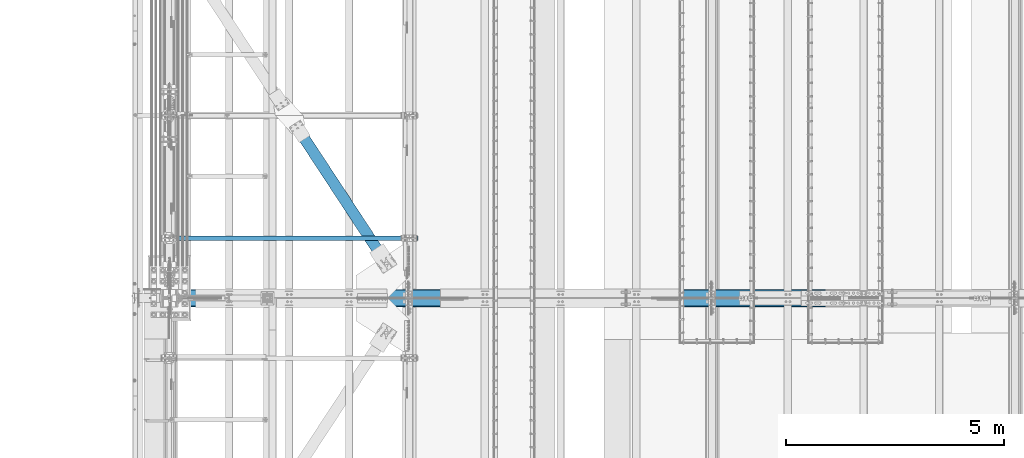
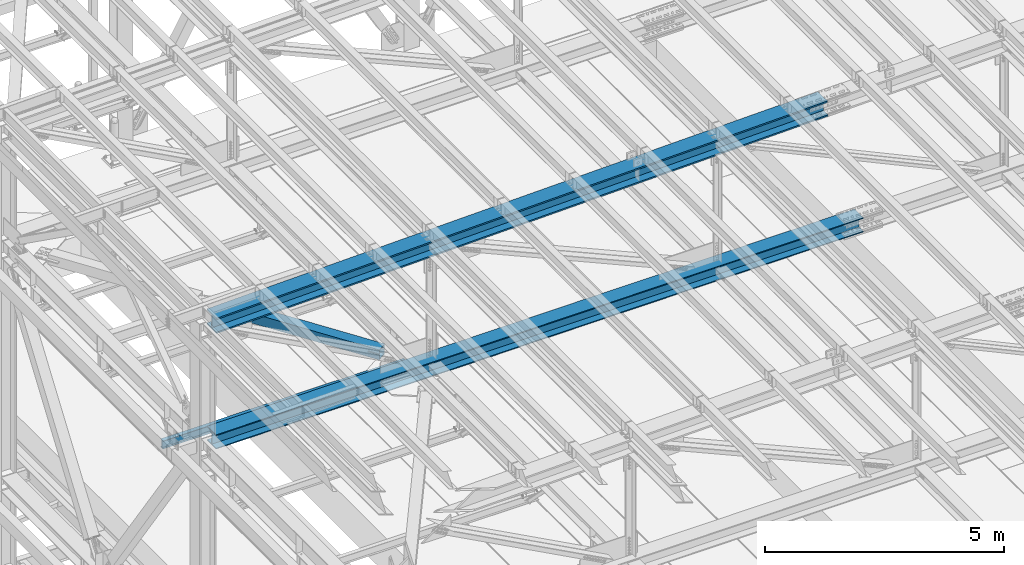
# One storey, part 1870 of 3843: 4 beams, 4 elements without a shape of their own.
"""IFC2X3 building model written with IfcOpenShell, lengths in millimetres."""

from ifc_helpers import new_model, si_unit, frame, origin_with_axes, place, context, subcontext, project, spatial, faceted_brep, material, type_object, element, aggregate, save


model = new_model("IFC2X3")

# Units and contexts
model_context = context("Model", 3, precision=1e-05, world=origin_with_axes())
body_context = subcontext(model_context, "Body", "Model", "MODEL_VIEW")
ifc_project = project(units=[si_unit("LENGTHUNIT", "METRE", prefix="MILLI"), si_unit("AREAUNIT", "SQUARE_METRE"), si_unit("VOLUMEUNIT", "CUBIC_METRE"), si_unit("MASSUNIT", "GRAM", prefix="KILO"), si_unit("TIMEUNIT", "SECOND"), si_unit("PLANEANGLEUNIT", "RADIAN"), si_unit("SOLIDANGLEUNIT", "STERADIAN"), si_unit("THERMODYNAMICTEMPERATUREUNIT", "DEGREE_CELSIUS"), si_unit("LUMINOUSINTENSITYUNIT", "LUMEN")], contexts=[model_context])

# Site, building, storey
site_placement = place(None, origin_with_axes())
site = spatial("IfcSite", under=ifc_project, at=site_placement, CompositionType="ELEMENT")
building_placement = place(site_placement, origin_with_axes())
building = spatial("IfcBuilding", under=site, at=building_placement, Name="Undefined", CompositionType="ELEMENT")
storey_placement = place(building_placement, origin_with_axes())
storey = spatial("IfcBuildingStorey", under=building, at=storey_placement, Name="Undefined", CompositionType="ELEMENT", Elevation=0.0)

# Assembly, beam
assembly_1_placement = place(storey_placement, origin_with_axes())
assembly_1 = element("IfcElementAssembly", 1, at=assembly_1_placement, inside=storey, Name="BEAM", AssemblyPlace="NOTDEFINED", PredefinedType="RIGID_FRAME")
ifc_material_1 = material(Name="STEEL/A992")
beam_type_1 = type_object("IfcBeamType", Name="W8X13", PredefinedType="NOTDEFINED")
beam_1_placement = place(assembly_1_placement, frame((36372.8, 68643.5, 41402.0), z_axis=(0.0, 0.0, 1.0), x_axis=(1.0, 0.0, 0.0)))
beam_1 = element("IfcBeam", 2, at=beam_1_placement, type_object=beam_type_1, material=ifc_material_1, Name="BEAM", ObjectType="W8X13", context=body_context, shape_type="Brep", body=[
    faceted_brep([(0.0, 50.7999999999993, -101.599999999999), (0.0, 50.7999999999993, -95.25), (5892.8, 50.7999999999993, -95.25), (5892.8, 50.7999999999993, -101.599999999999), (0.0, 3.17499999999927, -95.25), (5892.8, 3.17499999999927, -95.25), (-2.44140610448085e-05, 3.17500000000291, 95.2499999999927), (5892.8, 3.17499999999927, 95.25), (0.0, 50.7999999999993, 95.25), (5892.8, 50.7999999999993, 95.25), (0.0, 50.7999999999993, 101.599999999999), (5892.8, 50.7999999999993, 101.599999999999), (0.0, -50.7999999999993, 101.599999999999), (5892.8, -50.7999999999993, 101.599999999999), (0.0, -50.7999999999993, 95.25), (5892.8, -50.7999999999993, 95.25), (0.0, -3.17499999999927, 95.25), (5892.8, -3.17499999999927, 95.25), (0.0, -3.17499999999927, -95.25), (5892.8, -3.17499999999927, -95.25), (0.0, -50.7999999999993, -95.25), (5892.8, -50.7999999999993, -95.25), (0.0, -50.7999999999993, -101.599999999999), (5892.8, -50.7999999999993, -101.599999999999)], [[[0, 1, 2, 3]], [[1, 4, 5, 2]], [[4, 6, 7, 5]], [[6, 8, 9, 7]], [[8, 10, 11, 9]], [[10, 12, 13, 11]], [[12, 14, 15, 13]], [[14, 16, 17, 15]], [[16, 18, 19, 17]], [[18, 20, 21, 19]], [[20, 22, 23, 21]], [[22, 0, 3, 23]], [[5, 7, 9, 11, 13, 15, 17, 19, 21, 23, 3, 2]], [[22, 20, 18, 16, 14, 12, 10, 8, 6, 4, 1, 0]]]),
])
aggregate(assembly_1, [beam_1])

assembly_2_placement = place(storey_placement, origin_with_axes())
assembly_2 = element("IfcElementAssembly", 3, at=assembly_2_placement, inside=storey, Name="BEAM", AssemblyPlace="NOTDEFINED", PredefinedType="RIGID_FRAME")
beam_type_2 = type_object("IfcBeamType", Name="W14X193", PredefinedType="NOTDEFINED")
beam_2_placement = place(assembly_2_placement, frame((36581.3621945434, 67271.9, 45221.597899112), z_axis=(-0.0258271990066861, 0.0, 0.99966642225868), x_axis=(0.99966642225868, 0.0, 0.0258271990066833)))
beam_2 = element("IfcBeam", 4, at=beam_2_placement, type_object=beam_type_2, material=ifc_material_1, Name="BEAM", ObjectType="W14X193", context=body_context, shape_type="Brep", body=[
    faceted_brep([(12012.8182232807, 11.1125000000029, 163.773914461657), (12012.8182232807, 200.024999999994, 163.773914461657), (13514.4487999086, 200.024999999994, 162.270411304176), (13514.4487999086, 11.1125000000029, 162.270411304176), (10511.1872779887, 11.1125000000029, 164.847845374941), (10511.1872779887, 200.024999999994, 164.847845374941), (9009.55608692087, 11.1125000000029, 165.492203955546), (9009.55608692087, 200.024999999994, 165.492203955546), (7507.92477296503, 11.1125000000029, 165.706990152255), (7507.92477296503, 200.024999999994, 165.706990152255), (6006.29345900918, 11.1125000000029, 165.492203946436), (6006.29345900918, 200.024999999994, 165.492203946436), (4504.66226794132, 11.1125000000029, 164.847845356722), (4504.66226794132, 200.024999999994, 164.847845356722), (3003.03132264942, 11.1125000000029, 163.773914434329), (3003.03132264942, 200.024999999994, 163.773914434329), (1501.40074602143, 11.1125000000029, 162.270411267753), (1501.40074602143, 200.024999999994, 162.270411267753), (211.581490863464, 11.1125000000029, 160.610003854294), (211.581490863464, 200.024999999994, 160.610003854294), (12012.5430163565, 200.024999999994, -156.900967444722), (12012.5430163565, 11.1125000000029, -156.900967444722), (13514.0818573778, 11.1125000000029, -158.404378752195), (13514.0818573778, 200.024999999994, -158.404378752195), (10511.0038066938, 200.024999999994, -155.827102138595), (10511.0038066938, 11.1125000000029, -155.827102138595), (9009.46435127012, 200.024999999994, -155.182782922268), (9009.46435127012, 11.1125000000029, -155.182782922268), (7507.924772966, 200.024999999994, -154.968009846991), (7507.924772966, 11.1125000000029, -154.968009846991), (6006.38519466188, 200.024999999994, -155.182782931377), (6006.38519466188, 11.1125000000029, -155.182782931377), (4504.84573923824, 200.024999999994, -155.827102156807), (4504.84573923824, 11.1125000000029, -155.827102156807), (3003.30652957554, 200.024999999994, -156.900967472036), (3003.30652957554, 11.1125000000029, -156.900967472036), (1501.76768855423, 200.024999999994, -158.404378788626), (1501.76768855423, 11.1125000000029, -158.404378788626), (203.296307827331, 200.024999999994, -160.07592423819), (203.296307827331, 11.1125000000029, -160.07592423819), (12012.5116809146, -200.024999999994, -193.413453998415), (12012.5116809146, 200.024999999994, -193.413453998415), (13514.0400767926, 200.024999999994, -194.916854847725), (13514.0400767926, -200.024999999994, -194.916854847725), (10510.9829163978, -200.024999999994, -192.339596162405), (10510.9829163978, 200.024999999994, -192.339596162405), (9009.45390612177, -200.024999999994, -191.695281428161), (9009.45390612177, 200.024999999994, -191.695281428161), (7507.92477296611, -200.024999999994, -191.480509846908), (7507.92477296611, 200.024999999994, -191.480509846908), (6006.39563981046, -200.024999999994, -191.695281437278), (6006.39563981046, 200.024999999994, -191.695281437278), (4504.86662953442, -200.024999999994, -192.339596180624), (4504.86662953442, 200.024999999994, -192.339596180624), (3003.33786501762, -200.024999999994, -193.413454025736), (3003.33786501762, 200.024999999994, -193.413454025736), (1501.80946913965, -200.024999999994, -194.916854884155), (1501.80946913965, 200.024999999994, -194.916854884155), (202.352945402425, -200.024999999994, -196.589668525943), (202.352945402425, 200.024999999994, -196.589668525943), (12012.5430163565, -11.1125000000029, -156.900967444722), (12012.5430163565, -200.024999999994, -156.900967444722), (13514.0818573778, -200.024999999994, -158.404378752195), (13514.0818573778, -11.1125000000029, -158.404378752195), (10511.0038066938, -11.1125000000029, -155.827102138595), (10511.0038066938, -200.024999999994, -155.827102138595), (9009.46435127012, -11.1125000000029, -155.182782922268), (9009.46435127012, -200.024999999994, -155.182782922268), (7507.924772966, -11.1125000000029, -154.968009846991), (7507.924772966, -200.024999999994, -154.968009846991), (6006.38519466188, -11.1125000000029, -155.182782931377), (6006.38519466188, -200.024999999994, -155.182782931377), (4504.84573923824, -11.1125000000029, -155.827102156807), (4504.84573923824, -200.024999999994, -155.827102156807), (3003.30652957554, -11.1125000000029, -156.900967472036), (3003.30652957554, -200.024999999994, -156.900967472036), (1501.76768855423, -11.1125000000029, -158.404378788626), (1501.76768855423, -200.024999999994, -158.404378788626), (203.296307827331, -11.1125000000029, -160.07592423819), (203.296307827331, -200.024999999994, -160.07592423819), (12012.8182232807, -200.024999999994, 163.773914461657), (12012.8182232807, -11.1125000000029, 163.773914461657), (13514.4487999086, -11.1125000000029, 162.270411304176), (13514.4487999086, -200.024999999994, 162.270411304176), (10511.1872779887, -200.024999999994, 164.847845374941), (10511.1872779887, -11.1125000000029, 164.847845374941), (9009.55608692087, -200.024999999994, 165.492203955546), (9009.55608692087, -11.1125000000029, 165.492203955546), (7507.92477296503, -200.024999999994, 165.706990152255), (7507.92477296503, -11.1125000000029, 165.706990152255), (6006.29345900918, -200.024999999994, 165.492203946436), (6006.29345900918, -11.1125000000029, 165.492203946436), (4504.66226794132, -200.024999999994, 164.847845356722), (4504.66226794132, -11.1125000000029, 164.847845356722), (3003.03132264942, -200.024999999994, 163.773914434329), (3003.03132264942, -11.1125000000029, 163.773914434329), (1501.40074602143, -200.024999999994, 162.270411267753), (1501.40074602143, -11.1125000000029, 162.270411267753), (211.581490863464, -200.024999999994, 160.610003854294), (211.581490863464, -11.1125000000029, 160.610003854294), (212.524853288371, -200.024999999994, 197.123748142047), (212.524853288371, 200.024999999994, 197.123748142047), (1501.358965436, -200.024999999994, 198.782887363275), (1501.358965436, 200.024999999994, 198.782887363275), (3002.99998720733, -200.024999999994, 200.286400988021), (3002.99998720733, 200.024999999994, 200.286400988021), (4504.64137764513, -200.024999999994, 201.360339380546), (4504.64137764513, 200.024999999994, 201.360339380546), (6006.2830138606, -200.024999999994, 202.00470245233), (6006.2830138606, 200.024999999994, 202.00470245233), (7507.92477296492, -200.024999999994, 202.219490152165), (7507.92477296492, 200.024999999994, 202.219490152165), (9009.56653206923, -200.024999999994, 202.00470246144), (9009.56653206923, 200.024999999994, 202.00470246144), (10511.2081682847, -200.024999999994, 201.360339398751), (10511.2081682847, 200.024999999994, 201.360339398751), (12012.8495587225, -200.024999999994, 200.28640101535), (12012.8495587225, 200.024999999994, 200.28640101535), (13514.4905804938, -200.024999999994, 198.782887399706), (13514.4905804938, 200.024999999994, 198.782887399706), (15009.7811162431, -200.024999999994, 196.857973138111), (15009.7811162431, 200.024999999994, 196.857973138111), (15009.7289104314, 200.024999999994, 160.345510463165), (15009.7289104314, 11.1125000000029, 160.345510463165), (15009.2704072159, 11.1125000000029, -160.329161725502), (15009.2704072159, 200.024999999994, -160.329161725502), (15009.2182014042, 200.024999999994, -196.841624400455), (15009.2182014042, -200.024999999994, -196.841624400455), (15009.2704072159, -200.024999999994, -160.329161725502), (15009.2704072159, -11.1125000000029, -160.329161725502), (15009.7289104314, -11.1125000000029, 160.345510463165), (15009.7289104314, -200.024999999994, 160.345510463165)], [[[0, 1, 2, 3]], [[4, 5, 1, 0]], [[6, 7, 5, 4]], [[8, 9, 7, 6]], [[10, 11, 9, 8]], [[12, 13, 11, 10]], [[14, 15, 13, 12]], [[16, 17, 15, 14]], [[17, 16, 18, 19]], [[20, 21, 22, 23]], [[24, 25, 21, 20]], [[26, 27, 25, 24]], [[28, 29, 27, 26]], [[30, 31, 29, 28]], [[32, 33, 31, 30]], [[34, 35, 33, 32]], [[36, 37, 35, 34]], [[37, 36, 38, 39]], [[40, 41, 42, 43]], [[44, 45, 41, 40]], [[46, 47, 45, 44]], [[48, 49, 47, 46]], [[50, 51, 49, 48]], [[52, 53, 51, 50]], [[54, 55, 53, 52]], [[56, 57, 55, 54]], [[57, 56, 58, 59]], [[60, 61, 62, 63]], [[64, 65, 61, 60]], [[66, 67, 65, 64]], [[68, 69, 67, 66]], [[70, 71, 69, 68]], [[72, 73, 71, 70]], [[74, 75, 73, 72]], [[76, 77, 75, 74]], [[77, 76, 78, 79]], [[80, 81, 82, 83]], [[84, 85, 81, 80]], [[86, 87, 85, 84]], [[88, 89, 87, 86]], [[90, 91, 89, 88]], [[92, 93, 91, 90]], [[94, 95, 93, 92]], [[96, 97, 95, 94]], [[97, 96, 98, 99]], [[19, 18, 39, 38, 59, 58, 79, 78, 99, 98, 100, 101]], [[102, 103, 101, 100]], [[103, 102, 104, 105]], [[105, 104, 106, 107]], [[107, 106, 108, 109]], [[109, 108, 110, 111]], [[111, 110, 112, 113]], [[113, 112, 114, 115]], [[115, 114, 116, 117]], [[117, 116, 118, 119]], [[119, 118, 120, 121]], [[2, 1, 5, 7, 9, 11, 13, 15, 17, 19, 101, 103, 105, 107, 109, 111, 113, 115, 117, 119, 121, 122]], [[3, 2, 122, 123]], [[22, 21, 25, 27, 29, 31, 33, 35, 37, 39, 18, 16, 14, 12, 10, 8, 6, 4, 0, 3, 123, 124]], [[23, 22, 124, 125]], [[42, 41, 45, 47, 49, 51, 53, 55, 57, 59, 38, 36, 34, 32, 30, 28, 26, 24, 20, 23, 125, 126]], [[43, 42, 126, 127]], [[62, 61, 65, 67, 69, 71, 73, 75, 77, 79, 58, 56, 54, 52, 50, 48, 46, 44, 40, 43, 127, 128]], [[63, 62, 128, 129]], [[82, 81, 85, 87, 89, 91, 93, 95, 97, 99, 78, 76, 74, 72, 70, 68, 66, 64, 60, 63, 129, 130]], [[83, 82, 130, 131]], [[118, 116, 114, 112, 110, 108, 106, 104, 102, 100, 98, 96, 94, 92, 90, 88, 86, 84, 80, 83, 131, 120]], [[130, 129, 128, 127, 126, 125, 124, 123, 122, 121, 120, 131]]]),
])
aggregate(assembly_2, [beam_2])

assembly_3_placement = place(storey_placement, origin_with_axes())
assembly_3 = element("IfcElementAssembly", 5, at=assembly_3_placement, inside=storey, Name="BEAM", AssemblyPlace="NOTDEFINED", PredefinedType="RIGID_FRAME")
beam_type_3 = type_object("IfcBeamType", Name="W14X120", PredefinedType="NOTDEFINED")
beam_3_placement = place(assembly_3_placement, frame((36576.0006756785, 67271.9, 42246.5549761235), z_axis=(-0.00459547599882353, 0.0, 0.999989440744423), x_axis=(0.999989440744423, 0.0, 0.00459547599882549)))
beam_3 = element("IfcBeam", 6, at=beam_3_placement, type_object=beam_type_3, material=ifc_material_1, Name="BEAM", ObjectType="W14X120", context=body_context, shape_type="Brep", body=[
    faceted_brep([(9532.76941648932, 7.14375000000291, 166.108071863586), (9532.76941648932, 185.737500000003, 166.108071863586), (11121.6051002629, 185.737500000003, 165.386727314894), (11121.6051002629, 7.14375000000291, 165.386727314894), (7943.9335871618, 7.14375000000291, 166.348520054125), (7943.9335871618, 185.737500000003, 166.348520054125), (6355.09775783429, 7.14375000000291, 166.108071863229), (6355.09775783429, 185.737500000003, 166.108071863229), (4766.26207406071, 7.14375000000291, 165.386727314188), (4766.26207406071, 185.737500000003, 165.386727314188), (3177.42668139502, 7.14375000000291, 164.184486471255), (3177.42668139502, 185.737500000003, 164.184486471255), (1588.5917253911, 7.14375000000291, 162.501349446211), (1588.5917253911, 185.737500000003, 162.501349446211), (213.464742253811, 7.14375000000291, 160.628391324615), (213.464742253811, 185.737500000003, 160.628391324615), (12710.1493147809, 185.737500000003, -156.490381330463), (12710.1493147809, 7.14375000000291, -156.490381330463), (14298.8872114438, 7.14375000000291, -158.173415535042), (14298.8872114438, 185.737500000003, -158.173415535042), (11121.410981483, 185.737500000003, -155.288213930828), (11121.410981483, 7.14375000000291, -155.288213930828), (9532.67235709493, 185.737500000003, -154.56691344791), (9532.67235709493, 7.14375000000291, -154.56691344791), (7943.93358716184, 185.737500000003, -154.326479945965), (7943.93358716184, 7.14375000000291, -154.326479945965), (6355.19481722873, 185.737500000003, -154.566913448267), (6355.19481722873, 7.14375000000291, -154.566913448267), (4766.4561928407, 185.737500000003, -155.288213931548), (4766.4561928407, 7.14375000000291, -155.288213931548), (3177.71785954275, 185.737500000003, -156.49038133154), (3177.71785954275, 7.14375000000291, -156.49038133154), (1588.97996287991, 185.737500000003, -158.173415536483), (1588.97996287991, 7.14375000000291, -158.173415536483), (211.991061852903, 185.737500000003, -160.048909637866), (211.991061852903, 7.14375000000291, -160.048909637866), (12710.1276926412, -185.737500000003, -180.302871513835), (12710.1276926412, 185.737500000003, -180.302871513835), (14298.8583819273, 185.737500000003, -181.985898083265), (14298.8583819273, -185.737500000003, -181.985898083265), (11121.3965667221, -185.737500000003, -179.100709567887), (11121.3965667221, 185.737500000003, -179.100709567887), (9532.66514971416, -185.737500000003, -178.379412357179), (9532.66514971416, 185.737500000003, -178.379412357179), (7943.93358716183, -185.737500000003, -178.138979945972), (7943.93358716183, 185.737500000003, -178.138979945972), (6355.20202460951, -185.737500000003, -178.379412357535), (6355.20202460951, 185.737500000003, -178.379412357535), (4766.47060760158, -185.737500000003, -179.100709568607), (4766.47060760158, 185.737500000003, -179.100709568607), (3177.73948168242, -185.737500000003, -180.302871514912), (3177.73948168242, 185.737500000003, -180.302871514912), (1589.0087923964, -185.737500000003, -181.985898084706), (1589.0087923964, 185.737500000003, -181.985898084706), (211.881630139964, -185.737500000003, -183.861580501412), (211.881630139964, 185.737500000003, -183.861580501412), (12710.1493147809, -7.14375000000291, -156.490381330463), (12710.1493147809, -185.737500000003, -156.490381330463), (14298.8872114438, -185.737500000003, -158.173415535042), (14298.8872114438, -7.14375000000291, -158.173415535042), (11121.410981483, -7.14375000000291, -155.288213930828), (11121.410981483, -185.737500000003, -155.288213930828), (9532.67235709493, -7.14375000000291, -154.56691344791), (9532.67235709493, -185.737500000003, -154.56691344791), (7943.93358716184, -7.14375000000291, -154.326479945965), (7943.93358716184, -185.737500000003, -154.326479945965), (6355.19481722873, -7.14375000000291, -154.566913448267), (6355.19481722873, -185.737500000003, -154.566913448267), (4766.4561928407, -7.14375000000291, -155.288213931548), (4766.4561928407, -185.737500000003, -155.288213931548), (3177.71785954275, -7.14375000000291, -156.49038133154), (3177.71785954275, -185.737500000003, -156.49038133154), (1588.97996287991, -7.14375000000291, -158.173415536483), (1588.97996287991, -185.737500000003, -158.173415536483), (211.991061852903, -7.14375000000291, -160.048909637866), (211.991061852903, -185.737500000003, -160.048909637866), (12710.4404929286, -185.737500000003, 164.184486472332), (12710.4404929286, -7.14375000000291, 164.184486472332), (14299.2754489325, -7.14375000000291, 162.501349447644), (14299.2754489325, -185.737500000003, 162.501349447644), (11121.6051002629, -185.737500000003, 165.386727314894), (11121.6051002629, -7.14375000000291, 165.386727314894), (9532.76941648932, -185.737500000003, 166.108071863586), (9532.76941648932, -7.14375000000291, 166.108071863586), (7943.9335871618, -185.737500000003, 166.348520054125), (7943.9335871618, -7.14375000000291, 166.348520054125), (6355.09775783429, -185.737500000003, 166.108071863229), (6355.09775783429, -7.14375000000291, 166.108071863229), (4766.26207406071, -185.737500000003, 165.386727314188), (4766.26207406071, -7.14375000000291, 165.386727314188), (3177.42668139502, -185.737500000003, 164.184486471255), (3177.42668139502, -7.14375000000291, 164.184486471255), (1588.5917253911, -185.737500000003, 162.501349446211), (1588.5917253911, -7.14375000000291, 162.501349446211), (213.464742253811, -185.737500000003, 160.628391324615), (213.464742253811, -7.14375000000291, 160.628391324615), (213.57417396675, -185.737500000003, 184.441062188169), (213.57417396675, 185.737500000003, 184.441062188169), (1588.56289587461, -185.737500000003, 186.313831994434), (1588.56289587461, 185.737500000003, 186.313831994434), (3177.40505925533, -185.737500000003, 187.996976654635), (3177.40505925533, 185.737500000003, 187.996976654635), (4766.24765929981, -185.737500000003, 189.199222951247), (4766.24765929981, 185.737500000003, 189.199222951247), (6355.0905504535, -185.737500000003, 189.92057077249), (6355.0905504535, 185.737500000003, 189.92057077249), (7943.9335871618, -185.737500000003, 190.161020054133), (7943.9335871618, 185.737500000003, 190.161020054133), (9532.77662387009, -185.737500000003, 189.920570772854), (9532.77662387009, 185.737500000003, 189.920570772854), (11121.6195150238, -185.737500000003, 189.199222951967), (11121.6195150238, 185.737500000003, 189.199222951967), (12710.4621150683, -185.737500000003, 187.996976655719), (12710.4621150683, 185.737500000003, 187.996976655719), (14299.304278449, -185.737500000003, 186.313831995867), (14299.304278449, 185.737500000003, 186.313831995867), (15881.7957954726, -185.737500000003, 184.158438075872), (15881.7957954726, 185.737500000003, 184.158438075872), (14299.2754489325, 185.737500000003, 162.501349447644), (12710.4404929286, 185.737500000003, 164.184486472332), (15881.7597618329, 185.737500000003, 160.345965339853), (12710.4404929286, 7.14375000000291, 164.184486472332), (14299.2754489325, 7.14375000000291, 162.501349447644), (15881.7597618329, 7.14375000000291, 160.345965339853), (15881.2745088176, 7.14375000000291, -160.328667505208), (15881.2745088176, 185.737500000003, -160.328667505208), (15881.2384751779, 185.737500000003, -184.141140241234), (15881.2384751779, -185.737500000003, -184.141140241234), (15881.2745088176, -185.737500000003, -160.328667505208), (15881.2745088176, -7.14375000000291, -160.328667505208), (15881.7597618329, -7.14375000000291, 160.345965339853), (15881.7597618329, -185.737500000003, 160.345965339853)], [[[0, 1, 2, 3]], [[4, 5, 1, 0]], [[6, 7, 5, 4]], [[8, 9, 7, 6]], [[10, 11, 9, 8]], [[12, 13, 11, 10]], [[13, 12, 14, 15]], [[16, 17, 18, 19]], [[20, 21, 17, 16]], [[22, 23, 21, 20]], [[24, 25, 23, 22]], [[26, 27, 25, 24]], [[28, 29, 27, 26]], [[30, 31, 29, 28]], [[32, 33, 31, 30]], [[33, 32, 34, 35]], [[36, 37, 38, 39]], [[40, 41, 37, 36]], [[42, 43, 41, 40]], [[44, 45, 43, 42]], [[46, 47, 45, 44]], [[48, 49, 47, 46]], [[50, 51, 49, 48]], [[52, 53, 51, 50]], [[53, 52, 54, 55]], [[56, 57, 58, 59]], [[60, 61, 57, 56]], [[62, 63, 61, 60]], [[64, 65, 63, 62]], [[66, 67, 65, 64]], [[68, 69, 67, 66]], [[70, 71, 69, 68]], [[72, 73, 71, 70]], [[73, 72, 74, 75]], [[76, 77, 78, 79]], [[80, 81, 77, 76]], [[82, 83, 81, 80]], [[84, 85, 83, 82]], [[86, 87, 85, 84]], [[88, 89, 87, 86]], [[90, 91, 89, 88]], [[92, 93, 91, 90]], [[93, 92, 94, 95]], [[15, 14, 35, 34, 55, 54, 75, 74, 95, 94, 96, 97]], [[98, 99, 97, 96]], [[99, 98, 100, 101]], [[101, 100, 102, 103]], [[103, 102, 104, 105]], [[105, 104, 106, 107]], [[107, 106, 108, 109]], [[109, 108, 110, 111]], [[111, 110, 112, 113]], [[113, 112, 114, 115]], [[115, 114, 116, 117]], [[118, 119, 2, 1, 5, 7, 9, 11, 13, 15, 97, 99, 101, 103, 105, 107, 109, 111, 113, 115, 117, 120]], [[3, 2, 119, 121]], [[18, 17, 21, 23, 25, 27, 29, 31, 33, 35, 14, 12, 10, 8, 6, 4, 0, 3, 121, 122, 123, 124]], [[19, 18, 124, 125]], [[38, 37, 41, 43, 45, 47, 49, 51, 53, 55, 34, 32, 30, 28, 26, 24, 22, 20, 16, 19, 125, 126]], [[39, 38, 126, 127]], [[58, 57, 61, 63, 65, 67, 69, 71, 73, 75, 54, 52, 50, 48, 46, 44, 42, 40, 36, 39, 127, 128]], [[59, 58, 128, 129]], [[78, 77, 81, 83, 85, 87, 89, 91, 93, 95, 74, 72, 70, 68, 66, 64, 62, 60, 56, 59, 129, 130]], [[79, 78, 130, 131]], [[114, 112, 110, 108, 106, 104, 102, 100, 98, 96, 94, 92, 90, 88, 86, 84, 82, 80, 76, 79, 131, 116]], [[130, 129, 128, 127, 126, 125, 124, 123, 120, 117, 116, 131]], [[122, 118, 120, 123]], [[121, 119, 118, 122]]]),
])
aggregate(assembly_3, [beam_3])

assembly_4_placement = place(storey_placement, origin_with_axes())
assembly_4 = element("IfcElementAssembly", 7, at=assembly_4_placement, inside=storey, AssemblyPlace="NOTDEFINED", PredefinedType="RIGID_FRAME")
ifc_material_2 = material()
beam_type_4 = type_object("IfcBeamType", Name="HSS10X10X3/4", PredefinedType="NOTDEFINED")
beam_4_placement = place(assembly_4_placement, frame((39319.2000007859, 71450.200000464, 42246.55), z_axis=(0.835938629021657, 0.548822930014219, 0.0), x_axis=(0.548822930014218, -0.835938629021658, 0.0)))
beam_4 = element("IfcBeam", 8, at=beam_4_placement, type_object=beam_type_4, material=ifc_material_2, ObjectType="HSS10X10X3/4", context=body_context, shape_type="Brep", body=[
    faceted_brep([(390.494076155519, 1.58749999999418, 127.000000000829), (390.494076155526, 1.58749999999418, 107.950000000747), (642.906576168589, 1.58749999999418, 107.950000000936), (642.906576168702, 1.58749999999418, 127.000000001011), (645.944125913033, 0.98329378930066, 107.950000000936), (645.944125913142, 0.98329378930066, 127.000000001011), (648.519236244334, -0.737339924336993, 107.950000000928), (648.51923624444, -0.737339924336993, 127.000000001011), (650.239869957997, -3.31245025560929, 107.950000000936), (650.239869958106, -3.31245025560929, 127.000000001011), (642.906576168702, -14.2875000000058, 127.000000001011), (642.906576168589, -14.2875000000058, 107.950000000936), (390.494076155526, -14.2875000000058, 107.950000000747), (390.494076155519, -14.2875000000058, 127.000000000829), (645.944125913142, -13.6832937893123, 127.000000001011), (645.944125913033, -13.6832937893123, 107.950000000936), (648.51923624444, -11.9626600756746, 127.000000001011), (648.519236244334, -11.9626600756746, 107.950000000928), (650.239869958106, -9.38754974440235, 127.000000001011), (650.239869957997, -9.38754974440235, 107.950000000936), (650.844076168803, -6.35000000000582, 127.000000001026), (650.844076168702, -6.35000000000582, 107.950000000936), (390.494076155523, 1.58749999999418, -107.950000000194), (390.494076155523, 1.58749999999418, -127.000000000269), (642.906576167334, 1.58749999999418, -127.000000000095), (642.906576167436, 1.58749999999418, -107.950000000004), (645.944125911778, 0.98329378930066, -127.000000000095), (645.944125911868, 0.98329378930066, -107.950000000004), (648.519236243075, -0.737339924336993, -127.00000000008), (648.519236243181, -0.737339924336993, -107.950000000012), (650.239869956738, -3.31245025560929, -127.000000000087), (650.23986995684, -3.31245025560929, -107.950000000004), (642.906576167436, -14.2875000000058, -107.950000000004), (642.906576167334, -14.2875000000058, -127.000000000095), (390.494076155523, -14.2875000000058, -127.000000000269), (390.494076155523, -14.2875000000058, -107.950000000194), (645.944125911868, -13.6832937893123, -107.950000000004), (645.944125911778, -13.6832937893123, -127.000000000095), (648.519236243181, -11.9626600756746, -107.950000000012), (648.519236243075, -11.9626600756746, -127.00000000008), (650.23986995684, -9.38754974440235, -107.950000000004), (650.239869956738, -9.38754974440235, -127.000000000087), (650.844076167545, -6.35000000000582, -107.950000000004), (650.844076167443, -6.35000000000582, -127.000000000095), (390.494076155526, 107.949999999997, 107.950000000747), (390.494076155523, 107.949999999997, -107.950000000194), (3882.81644288582, 107.949999999997, -107.949999997705), (3882.81644288581, 107.949999999997, 107.950000003235), (390.494076155523, 127.0, -127.000000000269), (3882.81644288581, 127.0, -126.999999997788), (3882.81644288581, 1.58750000000146, -126.999999997788), (3630.40393108266, 1.58750000000146, -126.99999999797), (3624.93634139669, 0.499928791716229, -126.99999999797), (3620.30114267659, -2.59721197552426, -126.999999997977), (3617.2040019093, -7.23241069557116, -126.999999997985), (3616.11643070101, -12.6999996185259, -126.999999997977), (3617.2040019093, -18.167589304423, -126.999999997985), (3620.30114267659, -22.8027880244699, -126.999999997977), (3624.93634139669, -25.8999287917104, -126.99999999797), (3630.40393108266, -26.9874999999956, -126.99999999797), (3882.81644288581, -26.9874999999956, -126.999999997788), (3882.81644288581, -127.0, -126.999999997788), (390.494076155523, -127.0, -127.000000000269), (3882.81644288582, 1.58750000000146, -107.949999997705), (3630.40393108276, 1.58750000000146, -107.94999999788), (3624.93634139679, 0.499928791716229, -107.949999997894), (3620.30114267669, -2.59721197552426, -107.949999997894), (3617.2040019094, -7.23241069557116, -107.949999997894), (3616.1164307011, -12.6999996185259, -107.949999997902), (3617.2040019094, -18.167589304423, -107.949999997894), (3620.30114267669, -22.8027880244699, -107.949999997894), (3624.93634139679, -25.8999287917104, -107.949999997894), (3630.40393108276, -26.9874999999956, -107.94999999788), (3882.81644288582, -26.9874999999956, -107.949999997705), (390.494076155523, -107.949999999997, -107.950000000194), (390.494076155526, -107.949999999997, 107.950000000747), (3882.81644288581, -107.949999999997, 107.950000003235), (3882.81644288582, -107.949999999997, -107.949999997705), (3624.93634139806, 0.499928791716229, 127.000000003136), (3624.93634139796, 0.499928791716229, 107.950000003046), (3630.40393108393, 1.58750000000146, 107.950000003053), (3630.40393108402, 1.58750000000146, 127.000000003129), (3620.30114267795, -2.59721197552426, 127.000000003129), (3620.30114267785, -2.59721197552426, 107.950000003046), (3617.20400191067, -7.23241069557116, 127.000000003121), (3617.20400191057, -7.23241069557116, 107.950000003031), (3616.11643070237, -12.6999996185259, 127.000000003121), (3616.11643070227, -12.6999996185259, 107.950000003046), (3617.20400191067, -18.167589304423, 127.000000003121), (3617.20400191057, -18.167589304423, 107.950000003031), (3620.30114267795, -22.8027880244699, 127.000000003129), (3620.30114267785, -22.8027880244699, 107.950000003046), (3624.93634139806, -25.8999287917104, 127.000000003136), (3624.93634139796, -25.8999287917104, 107.950000003046), (3630.40393108402, -26.9874999999956, 127.000000003129), (3630.40393108393, -26.9874999999956, 107.950000003053), (3882.81644288581, -26.9874999999956, 127.000000003311), (3882.81644288581, -26.9874999999956, 107.950000003235), (3882.81644288581, -127.0, 127.000000003311), (390.494076155519, -127.0, 127.000000000829), (3882.81644288581, 1.58750000000146, 107.950000003235), (3882.81644288581, 1.58750000000146, 127.000000003311), (3882.81644288581, 127.0, 127.000000003311), (390.494076155519, 127.0, 127.000000000829)], [[[0, 1, 2, 3]], [[3, 2, 4, 5]], [[5, 4, 6, 7]], [[7, 6, 8, 9]], [[10, 11, 12, 13]], [[14, 15, 11, 10]], [[16, 17, 15, 14]], [[18, 19, 17, 16]], [[20, 21, 19, 18]], [[9, 8, 21, 20]], [[22, 23, 24, 25]], [[25, 24, 26, 27]], [[27, 26, 28, 29]], [[29, 28, 30, 31]], [[32, 33, 34, 35]], [[36, 37, 33, 32]], [[38, 39, 37, 36]], [[40, 41, 39, 38]], [[42, 43, 41, 40]], [[31, 30, 43, 42]], [[44, 45, 46, 47]], [[28, 26, 24, 23, 48, 49, 50, 51, 52, 53, 54, 55, 56, 57, 58, 59, 60, 61, 62, 34, 33, 37, 39, 41, 43, 30]], [[63, 64, 51, 50]], [[65, 52, 51, 64]], [[66, 53, 52, 65]], [[67, 54, 53, 66]], [[68, 55, 54, 67]], [[69, 56, 55, 68]], [[70, 57, 56, 69]], [[71, 58, 57, 70]], [[72, 59, 58, 71]], [[73, 60, 59, 72]], [[74, 75, 76, 77]], [[78, 79, 80, 81]], [[82, 83, 79, 78]], [[84, 85, 83, 82]], [[86, 87, 85, 84]], [[88, 89, 87, 86]], [[90, 91, 89, 88]], [[92, 93, 91, 90]], [[94, 95, 93, 92]], [[96, 97, 95, 94]], [[98, 61, 60, 73, 77, 76, 97, 96]], [[99, 62, 61, 98]], [[75, 74, 35, 34, 62, 99, 13, 12]], [[6, 4, 2, 1, 44, 47, 100, 80, 79, 83, 85, 87, 89, 91, 93, 95, 97, 76, 75, 12, 11, 15, 17, 19, 21, 8]], [[101, 81, 80, 100]], [[47, 46, 63, 50, 49, 102, 101, 100]], [[48, 103, 102, 49]], [[16, 14, 10, 13, 99, 98, 96, 94, 92, 90, 88, 86, 84, 82, 78, 81, 101, 102, 103, 0, 3, 5, 7, 9, 20, 18]], [[103, 48, 23, 22, 45, 44, 1, 0]], [[38, 36, 32, 35, 74, 77, 73, 72, 71, 70, 69, 68, 67, 66, 65, 64, 63, 46, 45, 22, 25, 27, 29, 31, 42, 40]]]),
])
aggregate(assembly_4, [beam_4])

save(model, "model.ifc")
